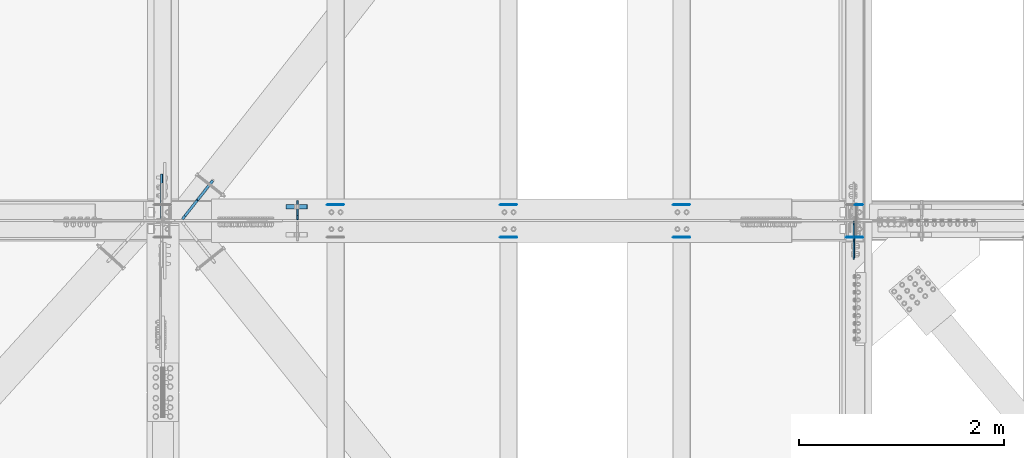
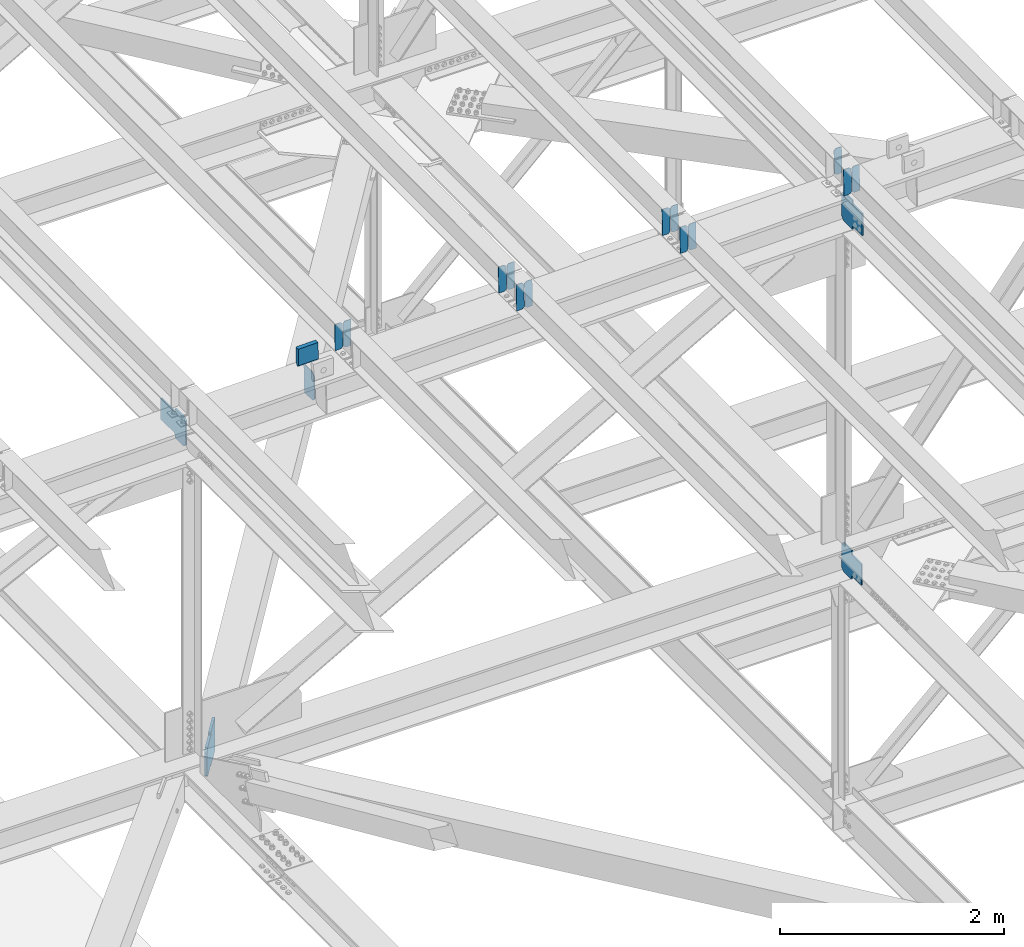
# One storey, part 3297 of 3843: 19 plates, 9 elements without a shape of their own.
"""IFC2X3 building model written with IfcOpenShell, lengths in millimetres."""

from ifc_helpers import new_model, si_unit, frame, origin_with_axes, place, context, subcontext, project, spatial, faceted_brep, material, type_object, element, aggregate, save


model = new_model("IFC2X3")

# Units and contexts
model_context = context("Model", 3, precision=1e-05, world=origin_with_axes())
body_context = subcontext(model_context, "Body", "Model", "MODEL_VIEW")
ifc_project = project(units=[si_unit("LENGTHUNIT", "METRE", prefix="MILLI"), si_unit("AREAUNIT", "SQUARE_METRE"), si_unit("VOLUMEUNIT", "CUBIC_METRE"), si_unit("MASSUNIT", "GRAM", prefix="KILO"), si_unit("TIMEUNIT", "SECOND"), si_unit("PLANEANGLEUNIT", "RADIAN"), si_unit("SOLIDANGLEUNIT", "STERADIAN"), si_unit("THERMODYNAMICTEMPERATUREUNIT", "DEGREE_CELSIUS"), si_unit("LUMINOUSINTENSITYUNIT", "LUMEN")], contexts=[model_context])

# Site, building, storey
site_placement = place(None, origin_with_axes())
site = spatial("IfcSite", under=ifc_project, at=site_placement, CompositionType="ELEMENT")
building_placement = place(site_placement, origin_with_axes())
building = spatial("IfcBuilding", under=site, at=building_placement, Name="Undefined", CompositionType="ELEMENT")
storey_placement = place(building_placement, origin_with_axes())
storey = spatial("IfcBuildingStorey", under=building, at=storey_placement, Name="Undefined", CompositionType="ELEMENT", Elevation=0.0)

# Assembly, plates
assembly_1_placement = place(storey_placement, origin_with_axes())
assembly_1 = element("IfcElementAssembly", 1, at=assembly_1_placement, inside=storey, Name="BEAM", AssemblyPlace="NOTDEFINED", PredefinedType="RIGID_FRAME")
ifc_material = material(Name="STEEL/A572-50")
plate_type_1 = type_object("IfcPlateType", PredefinedType="NOTDEFINED")
plate_1_placement = place(assembly_1_placement, frame((75405.9964782679, 33684.1789093083, 46268.5635563164), z_axis=(-0.021152098282546, -0.00202236699979404, 0.999774223897558), x_axis=(-0.999776269341419, 4.27870000128944e-05, -0.0211520550071887)))
plate_1 = element("IfcPlate", 2, at=plate_1_placement, type_object=plate_type_1, material=ifc_material, Name="PLATE", context=body_context, shape_type="Brep", body=[
    faceted_brep([(0.0, -3.17499999999927, 0.0), (6.83940015733242e-10, -3.17499999996653, 288.924999998613), (6.54836185276508e-10, 3.17500000001746, 288.924999998591), (0.0, 3.17499999999927, 0.0), (60.3250007643655, -3.17500000017753, 288.924999998606), (60.3250007643219, 3.17499999979918, 288.924999998584), (79.3750000013097, -3.17500000025029, 269.875000761494), (79.375000001266, 3.17499999972642, 269.875000761487), (79.375000000713, -3.17500000026484, 19.0499992370605), (79.3750000006985, 3.17499999971187, 19.0499992370533), (60.325000763667, -3.17500000020664, -1.45519152283669e-11), (60.3250007636234, 3.17499999977736, -3.63797880709171e-11)], [[[0, 1, 2, 3]], [[1, 4, 5, 2]], [[4, 6, 7, 5]], [[6, 8, 9, 7]], [[8, 10, 11, 9]], [[10, 0, 3, 11]], [[5, 7, 9, 11, 3, 2]], [[10, 8, 6, 4, 1, 0]]]),
])
plate_2_placement = place(assembly_1_placement, frame((75320.2906575777, 33684.1825772123, 46266.7502964254), z_axis=(-0.021152098282546, -0.00202236699979404, 0.999774223897558), x_axis=(-0.999776269341419, 4.27870000128944e-05, -0.0211520550071887)))
plate_2 = element("IfcPlate", 3, at=plate_2_placement, type_object=plate_type_1, material=ifc_material, Name="PLATE", context=body_context, shape_type="Brep", body=[
    faceted_brep([(4.36557456851006e-11, -3.17499999998836, 19.0499992370969), (6.11180439591408e-10, -3.17499999996653, 269.875000761516), (5.96628524363041e-10, 3.17500000001746, 269.875000761502), (1.45519152283669e-11, 3.17499999998836, 19.0499992370824), (19.0499992376572, -3.17500000003201, 288.924999998606), (19.0499992376281, 3.1749999999447, 288.924999998584), (79.3750000013242, -3.17500000025029, 288.924999998591), (79.3750000013097, 3.1749999997337, 288.92499999857), (79.3750000006548, -3.17500000026484, -2.18278728425503e-11), (79.3750000006403, 3.17499999969732, -2.91038304567337e-11), (19.0499992370023, -3.17500000005384, 0.0), (19.0499992369587, 3.17499999992287, -1.45519152283669e-11)], [[[0, 1, 2, 3]], [[1, 4, 5, 2]], [[4, 6, 7, 5]], [[6, 8, 9, 7]], [[8, 10, 11, 9]], [[10, 0, 3, 11]], [[5, 7, 9, 11, 3, 2]], [[10, 8, 6, 4, 1, 0]]]),
])
aggregate(assembly_1, [plate_1, plate_2])

assembly_2_placement = place(storey_placement, origin_with_axes())
assembly_2 = element("IfcElementAssembly", 4, at=assembly_2_placement, inside=storey, Name="BEAM", AssemblyPlace="NOTDEFINED", PredefinedType="RIGID_FRAME")
plate_3_placement = place(assembly_2_placement, frame((75405.9964782771, 34003.091399023, 46270.7774351257), z_axis=(-0.0211520977008331, -0.00680297999754112, 0.999753123639035), x_axis=(-0.999776269353726, 0.000143930000091341, -0.021151608007443)))
plate_3 = element("IfcPlate", 5, at=plate_3_placement, type_object=plate_type_1, material=ifc_material, Name="PLATE", context=body_context, shape_type="Brep", body=[
    faceted_brep([(0.0, -3.17499999999927, 0.0), (6.83940015733242e-10, -3.17499999996653, 288.924999998613), (6.54836185276508e-10, 3.17500000001746, 288.924999998591), (0.0, 3.17499999999927, 0.0), (60.3250007643655, -3.17500000017753, 288.924999998606), (60.3250007643219, 3.17499999979918, 288.924999998584), (79.3750000013097, -3.17500000025029, 269.875000761494), (79.375000001266, 3.17499999972642, 269.875000761487), (79.375000000713, -3.17500000026484, 19.0499992370605), (79.3750000006985, 3.17499999971187, 19.0499992370533), (60.325000763667, -3.17500000020664, -1.45519152283669e-11), (60.3250007636234, 3.17499999977736, -3.63797880709171e-11)], [[[0, 1, 2, 3]], [[1, 4, 5, 2]], [[4, 6, 7, 5]], [[6, 8, 9, 7]], [[8, 10, 11, 9]], [[10, 0, 3, 11]], [[5, 7, 9, 11, 3, 2]], [[10, 8, 6, 4, 1, 0]]]),
])
plate_4_placement = place(assembly_2_placement, frame((75320.2906575868, 34003.1037373807, 46268.9642135039), z_axis=(-0.0211520977008331, -0.00680297999754112, 0.999753123639035), x_axis=(-0.999776269353726, 0.000143930000091341, -0.021151608007443)))
plate_4 = element("IfcPlate", 6, at=plate_4_placement, type_object=plate_type_1, material=ifc_material, Name="PLATE", context=body_context, shape_type="Brep", body=[
    faceted_brep([(4.36557456851006e-11, -3.17499999998836, 19.0499992370969), (6.11180439591408e-10, -3.17499999996653, 269.875000761516), (5.96628524363041e-10, 3.17500000001746, 269.875000761502), (1.45519152283669e-11, 3.17499999998836, 19.0499992370824), (19.0499992376572, -3.17500000003201, 288.924999998606), (19.0499992376281, 3.1749999999447, 288.924999998584), (79.3750000013242, -3.17500000025029, 288.924999998591), (79.3750000013097, 3.1749999997337, 288.92499999857), (79.3750000006548, -3.17500000026484, -2.18278728425503e-11), (79.3750000006403, 3.17499999969732, -2.91038304567337e-11), (19.0499992370023, -3.17500000005384, 0.0), (19.0499992369587, 3.17499999992287, -1.45519152283669e-11)], [[[0, 1, 2, 3]], [[1, 4, 5, 2]], [[4, 6, 7, 5]], [[6, 8, 9, 7]], [[8, 10, 11, 9]], [[10, 0, 3, 11]], [[5, 7, 9, 11, 3, 2]], [[10, 8, 6, 4, 1, 0]]]),
])
aggregate(assembly_2, [plate_3, plate_4])

# Assembly, plate
assembly_3_placement = place(storey_placement, origin_with_axes())
assembly_3 = element("IfcElementAssembly", 7, at=assembly_3_placement, inside=storey, Name="BEAM", AssemblyPlace="NOTDEFINED", PredefinedType="RIGID_FRAME")
plate_5_placement = place(assembly_3_placement, frame((77095.0964783511, 34002.9786941155, 46307.2647120351), z_axis=(-0.0211520979019697, -0.00640368699966348, 0.999755760947221), x_axis=(-0.999776269349471, 0.000135482000054671, -0.0211516640074006)))
plate_5 = element("IfcPlate", 8, at=plate_5_placement, type_object=plate_type_1, material=ifc_material, Name="PLATE", context=body_context, shape_type="Brep", body=[
    faceted_brep([(0.0, -3.17499999999927, 0.0), (6.83940015733242e-10, -3.17499999996653, 288.924999998613), (6.54836185276508e-10, 3.17500000001746, 288.924999998591), (0.0, 3.17499999999927, 0.0), (60.3250007643655, -3.17500000017753, 288.924999998606), (60.3250007643219, 3.17499999979918, 288.924999998584), (79.3750000013097, -3.17500000025029, 269.875000761494), (79.375000001266, 3.17499999972642, 269.875000761487), (79.375000000713, -3.17500000026484, 19.0499992370605), (79.3750000006985, 3.17499999971187, 19.0499992370533), (60.325000763667, -3.17500000020664, -1.45519152283669e-11), (60.3250007636234, 3.17499999977736, -3.63797880709171e-11)], [[[0, 1, 2, 3]], [[1, 4, 5, 2]], [[4, 6, 7, 5]], [[6, 8, 9, 7]], [[8, 10, 11, 9]], [[10, 0, 3, 11]], [[5, 7, 9, 11, 3, 2]], [[10, 8, 6, 4, 1, 0]]]),
])
aggregate(assembly_3, [plate_5])

# Assembly, plates
assembly_4_placement = place(storey_placement, origin_with_axes())
assembly_4 = element("IfcElementAssembly", 9, at=assembly_4_placement, inside=storey, Name="BEAM", AssemblyPlace="NOTDEFINED", PredefinedType="RIGID_FRAME")
plate_6_placement = place(assembly_4_placement, frame((77095.096478274, 33684.2219342469, 46305.9063409992), z_axis=(-0.0211520976594328, -0.00216626100104622, 0.999773922483419), x_axis=(-0.999776269348977, 4.5491000049241e-05, -0.0211520490073722)))
plate_6 = element("IfcPlate", 10, at=plate_6_placement, type_object=plate_type_1, material=ifc_material, Name="PLATE", context=body_context, shape_type="Brep", body=[
    faceted_brep([(0.0, -3.17499999999927, 0.0), (6.83940015733242e-10, -3.17499999996653, 288.924999998613), (6.54836185276508e-10, 3.17500000001746, 288.924999998591), (0.0, 3.17499999999927, 0.0), (60.3250007643655, -3.17500000017753, 288.924999998606), (60.3250007643219, 3.17499999979918, 288.924999998584), (79.3750000013097, -3.17500000025029, 269.875000761494), (79.375000001266, 3.17499999972642, 269.875000761487), (79.375000000713, -3.17500000026484, 19.0499992370605), (79.3750000006985, 3.17499999971187, 19.0499992370533), (60.325000763667, -3.17500000020664, -1.45519152283669e-11), (60.3250007636234, 3.17499999977736, -3.63797880709171e-11)], [[[0, 1, 2, 3]], [[1, 4, 5, 2]], [[4, 6, 7, 5]], [[6, 8, 9, 7]], [[8, 10, 11, 9]], [[10, 0, 3, 11]], [[5, 7, 9, 11, 3, 2]], [[10, 8, 6, 4, 1, 0]]]),
])
plate_7_placement = place(assembly_4_placement, frame((77009.3906575827, 33684.2258631284, 46304.0930816536), z_axis=(-0.0211520976594328, -0.00216626100104622, 0.999773922483419), x_axis=(-0.999776269348977, 4.5491000049241e-05, -0.0211520490073722)))
plate_7 = element("IfcPlate", 11, at=plate_7_placement, type_object=plate_type_1, material=ifc_material, Name="PLATE", context=body_context, shape_type="Brep", body=[
    faceted_brep([(4.36557456851006e-11, -3.17499999998836, 19.0499992370969), (6.11180439591408e-10, -3.17499999996653, 269.875000761516), (5.96628524363041e-10, 3.17500000001746, 269.875000761502), (1.45519152283669e-11, 3.17499999998836, 19.0499992370824), (19.0499992376572, -3.17500000003201, 288.924999998606), (19.0499992376281, 3.1749999999447, 288.924999998584), (79.3750000013242, -3.17500000025029, 288.924999998591), (79.3750000013097, 3.1749999997337, 288.92499999857), (79.3750000006548, -3.17500000026484, -2.18278728425503e-11), (79.3750000006403, 3.17499999969732, -2.91038304567337e-11), (19.0499992370023, -3.17500000005384, 0.0), (19.0499992369587, 3.17499999992287, -1.45519152283669e-11)], [[[0, 1, 2, 3]], [[1, 4, 5, 2]], [[4, 6, 7, 5]], [[6, 8, 9, 7]], [[8, 10, 11, 9]], [[10, 0, 3, 11]], [[5, 7, 9, 11, 3, 2]], [[10, 8, 6, 4, 1, 0]]]),
])
aggregate(assembly_4, [plate_6, plate_7])

assembly_5_placement = place(storey_placement, origin_with_axes())
assembly_5 = element("IfcElementAssembly", 12, at=assembly_5_placement, inside=storey, Name="BEAM", AssemblyPlace="NOTDEFINED", PredefinedType="RIGID_FRAME")
plate_8_placement = place(assembly_5_placement, frame((73716.8964782651, 34003.1977922987, 46234.280966957), z_axis=(-0.0211520979699417, -0.00714367000215133, 0.999750747301731), x_axis=(-0.999776269348033, 0.000151137000043463, -0.0211515580073186)))
plate_8 = element("IfcPlate", 13, at=plate_8_placement, type_object=plate_type_1, material=ifc_material, Name="PLATE", context=body_context, shape_type="Brep", body=[
    faceted_brep([(0.0, -3.17499999999927, 0.0), (6.83940015733242e-10, -3.17499999996653, 288.924999998613), (6.54836185276508e-10, 3.17500000001746, 288.924999998591), (0.0, 3.17499999999927, 0.0), (60.3250007643655, -3.17500000017753, 288.924999998606), (60.3250007643219, 3.17499999979918, 288.924999998584), (79.3750000013097, -3.17500000025029, 269.875000761494), (79.375000001266, 3.17499999972642, 269.875000761487), (79.375000000713, -3.17500000026484, 19.0499992370605), (79.3750000006985, 3.17499999971187, 19.0499992370533), (60.325000763667, -3.17500000020664, -1.45519152283669e-11), (60.3250007636234, 3.17499999977736, -3.63797880709171e-11)], [[[0, 1, 2, 3]], [[1, 4, 5, 2]], [[4, 6, 7, 5]], [[6, 8, 9, 7]], [[8, 10, 11, 9]], [[10, 0, 3, 11]], [[5, 7, 9, 11, 3, 2]], [[10, 8, 6, 4, 1, 0]]]),
])
plate_9_placement = place(assembly_5_placement, frame((73631.1906575739, 34003.2107485552, 46232.4677496438), z_axis=(-0.0211520979699417, -0.00714367000215133, 0.999750747301731), x_axis=(-0.999776269348033, 0.000151137000043463, -0.0211515580073186)))
plate_9 = element("IfcPlate", 14, at=plate_9_placement, type_object=plate_type_1, material=ifc_material, Name="PLATE", context=body_context, shape_type="Brep", body=[
    faceted_brep([(4.36557456851006e-11, -3.17499999998836, 19.0499992370969), (6.11180439591408e-10, -3.17499999996653, 269.875000761516), (5.96628524363041e-10, 3.17500000001746, 269.875000761502), (1.45519152283669e-11, 3.17499999998836, 19.0499992370824), (19.0499992376572, -3.17500000003201, 288.924999998606), (19.0499992376281, 3.1749999999447, 288.924999998584), (79.3750000013242, -3.17500000025029, 288.924999998591), (79.3750000013097, 3.1749999997337, 288.92499999857), (79.3750000006548, -3.17500000026484, -2.18278728425503e-11), (79.3750000006403, 3.17499999969732, -2.91038304567337e-11), (19.0499992370023, -3.17500000005384, 0.0), (19.0499992369587, 3.17499999992287, -1.45519152283669e-11)], [[[0, 1, 2, 3]], [[1, 4, 5, 2]], [[4, 6, 7, 5]], [[6, 8, 9, 7]], [[8, 10, 11, 9]], [[10, 0, 3, 11]], [[5, 7, 9, 11, 3, 2]], [[10, 8, 6, 4, 1, 0]]]),
])
aggregate(assembly_5, [plate_8, plate_9])

assembly_6_placement = place(storey_placement, origin_with_axes())
assembly_6 = element("IfcElementAssembly", 15, at=assembly_6_placement, inside=storey, Name="BEAM", AssemblyPlace="NOTDEFINED", PredefinedType="RIGID_FRAME")
plate_10_placement = place(assembly_6_placement, frame((73716.8964782659, 33684.1789031377, 46232.8275160392), z_axis=(-0.021152098282546, -0.00202236699979404, 0.999774223897558), x_axis=(-0.999776269341419, 4.27870000128944e-05, -0.0211520550071887)))
plate_10 = element("IfcPlate", 16, at=plate_10_placement, type_object=plate_type_1, material=ifc_material, Name="PLATE", context=body_context, shape_type="Brep", body=[
    faceted_brep([(0.0, -3.17499999999927, 0.0), (6.83940015733242e-10, -3.17499999996653, 288.924999998613), (6.54836185276508e-10, 3.17500000001746, 288.924999998591), (0.0, 3.17499999999927, 0.0), (60.3250007643655, -3.17500000017753, 288.924999998606), (60.3250007643219, 3.17499999979918, 288.924999998584), (79.3750000013097, -3.17500000025029, 269.875000761494), (79.375000001266, 3.17499999972642, 269.875000761487), (79.375000000713, -3.17500000026484, 19.0499992370605), (79.3750000006985, 3.17499999971187, 19.0499992370533), (60.325000763667, -3.17500000020664, -1.45519152283669e-11), (60.3250007636234, 3.17499999977736, -3.63797880709171e-11)], [[[0, 1, 2, 3]], [[1, 4, 5, 2]], [[4, 6, 7, 5]], [[6, 8, 9, 7]], [[8, 10, 11, 9]], [[10, 0, 3, 11]], [[5, 7, 9, 11, 3, 2]], [[10, 8, 6, 4, 1, 0]]]),
])
plate_11_placement = place(assembly_6_placement, frame((73631.1906575747, 33684.182571042, 46231.0142561484), z_axis=(-0.021152098282546, -0.00202236699979404, 0.999774223897558), x_axis=(-0.999776269341419, 4.27870000128944e-05, -0.0211520550071887)))
plate_11 = element("IfcPlate", 17, at=plate_11_placement, type_object=plate_type_1, material=ifc_material, Name="PLATE", context=body_context, shape_type="Brep", body=[
    faceted_brep([(4.36557456851006e-11, -3.17499999998836, 19.0499992370969), (6.11180439591408e-10, -3.17499999996653, 269.875000761516), (5.96628524363041e-10, 3.17500000001746, 269.875000761502), (1.45519152283669e-11, 3.17499999998836, 19.0499992370824), (19.0499992376572, -3.17500000003201, 288.924999998606), (19.0499992376281, 3.1749999999447, 288.924999998584), (79.3750000013242, -3.17500000025029, 288.924999998591), (79.3750000013097, 3.1749999997337, 288.92499999857), (79.3750000006548, -3.17500000026484, -2.18278728425503e-11), (79.3750000006403, 3.17499999969732, -2.91038304567337e-11), (19.0499992370023, -3.17500000005384, 0.0), (19.0499992369587, 3.17499999992287, -1.45519152283669e-11)], [[[0, 1, 2, 3]], [[1, 4, 5, 2]], [[4, 6, 7, 5]], [[6, 8, 9, 7]], [[8, 10, 11, 9]], [[10, 0, 3, 11]], [[5, 7, 9, 11, 3, 2]], [[10, 8, 6, 4, 1, 0]]]),
])
aggregate(assembly_6, [plate_10, plate_11])

assembly_7_placement = place(storey_placement, origin_with_axes())
assembly_7 = element("IfcElementAssembly", 18, at=assembly_7_placement, inside=storey, Name="BEAM", AssemblyPlace="NOTDEFINED", PredefinedType="RIGID_FRAME")
plate_12_placement = place(assembly_7_placement, frame((72027.7964782784, 34003.2790771855, 46197.7739598394), z_axis=(-0.0211520982902439, -0.0074183040013959, 0.999748747187844), x_axis=(-0.999776269341256, 0.000156948000085566, -0.0211515160072627)))
plate_12 = element("IfcPlate", 19, at=plate_12_placement, type_object=plate_type_1, material=ifc_material, Name="PLATE", context=body_context, shape_type="Brep", body=[
    faceted_brep([(0.0, -3.17499999999927, 0.0), (6.83940015733242e-10, -3.17499999996653, 288.924999998613), (6.54836185276508e-10, 3.17500000001746, 288.924999998591), (0.0, 3.17499999999927, 0.0), (60.3250007643655, -3.17500000017753, 288.924999998606), (60.3250007643219, 3.17499999979918, 288.924999998584), (79.3750000013097, -3.17500000025029, 269.875000761494), (79.375000001266, 3.17499999972642, 269.875000761487), (79.375000000713, -3.17500000026484, 19.0499992370605), (79.3750000006985, 3.17499999971187, 19.0499992370533), (60.325000763667, -3.17500000020664, -1.45519152283669e-11), (60.3250007636234, 3.17499999977736, -3.63797880709171e-11)], [[[0, 1, 2, 3]], [[1, 4, 5, 2]], [[4, 6, 7, 5]], [[6, 8, 9, 7]], [[8, 10, 11, 9]], [[10, 0, 3, 11]], [[5, 7, 9, 11, 3, 2]], [[10, 8, 6, 4, 1, 0]]]),
])
plate_13_placement = place(assembly_7_placement, frame((71942.0906575872, 34003.2925315358, 46195.9607461541), z_axis=(-0.0211520982902439, -0.0074183040013959, 0.999748747187844), x_axis=(-0.999776269341256, 0.000156948000085566, -0.0211515160072627)))
plate_13 = element("IfcPlate", 20, at=plate_13_placement, type_object=plate_type_1, material=ifc_material, Name="PLATE", context=body_context, shape_type="Brep", body=[
    faceted_brep([(4.36557456851006e-11, -3.17499999998836, 19.0499992370969), (6.11180439591408e-10, -3.17499999996653, 269.875000761516), (5.96628524363041e-10, 3.17500000001746, 269.875000761502), (1.45519152283669e-11, 3.17499999998836, 19.0499992370824), (19.0499992376572, -3.17500000003201, 288.924999998606), (19.0499992376281, 3.1749999999447, 288.924999998584), (79.3750000013242, -3.17500000025029, 288.924999998591), (79.3750000013097, 3.1749999997337, 288.92499999857), (79.3750000006548, -3.17500000026484, -2.18278728425503e-11), (79.3750000006403, 3.17499999969732, -2.91038304567337e-11), (19.0499992370023, -3.17500000005384, 0.0), (19.0499992369587, 3.17499999992287, -1.45519152283669e-11)], [[[0, 1, 2, 3]], [[1, 4, 5, 2]], [[4, 6, 7, 5]], [[6, 8, 9, 7]], [[8, 10, 11, 9]], [[10, 0, 3, 11]], [[5, 7, 9, 11, 3, 2]], [[10, 8, 6, 4, 1, 0]]]),
])
aggregate(assembly_7, [plate_12, plate_13])

assembly_8_placement = place(storey_placement, origin_with_axes())
assembly_8 = element("IfcElementAssembly", 21, at=assembly_8_placement, inside=storey, Name="BEAM", AssemblyPlace="NOTDEFINED", PredefinedType="RIGID_FRAME")
plate_type_2 = type_object("IfcPlateType", PredefinedType="NOTDEFINED")
plate_14_placement = place(assembly_8_placement, frame((71571.7735521455, 33856.6125, 45819.9763019932), z_axis=(-0.0216342480057937, 0.0, 0.999765952267441), x_axis=(0.0, 1.0, 0.0)))
plate_14 = element("IfcPlate", 22, at=plate_14_placement, type_object=plate_type_2, material=ifc_material, Name="PL", context=body_context, shape_type="Brep", body=[
    faceted_brep([(0.0, -4.76250000000073, 38.0999999999985), (0.0, -4.76249999810534, 279.400001530797), (0.0, 4.76250000185973, 279.400001530805), (0.0, 4.76250000000073, 38.0999999999985), (38.0999984741211, -4.76249999785796, 317.500000005042), (38.0999984741211, 4.76250000210712, 317.50000000505), (184.150000000009, -4.76249999999709, 317.5), (184.150000000009, 4.76249999999709, 317.5), (184.150000000009, -4.76249999999709, 0.0), (184.150000000009, 4.76249999999709, 0.0), (38.0999984741211, -4.76249999996799, 0.0), (38.0999984741211, 4.76249999998254, 0.0)], [[[0, 1, 2, 3]], [[1, 4, 5, 2]], [[4, 6, 7, 5]], [[6, 8, 9, 7]], [[8, 10, 11, 9]], [[10, 0, 3, 11]], [[5, 7, 9, 11, 3, 2]], [[10, 8, 6, 4, 1, 0]]]),
])
plate_type_3 = type_object("IfcPlateType", PredefinedType="NOTDEFINED")
plate_15_placement = place(assembly_8_placement, frame((71458.4330476478, 33981.628125, 46376.3164907603), z_axis=(0.0217666070074993, 0.0, -0.999763079343992), x_axis=(0.999763079343992, 0.0, 0.0217666070075027)))
plate_15 = element("IfcPlate", 23, at=plate_15_placement, type_object=plate_type_3, material=ifc_material, Name="PLATE", context=body_context, shape_type="Brep", body=[
    faceted_brep([(203.200005058941, -22.2250000000058, -1.16415321826935e-10), (7.27595761418343e-12, -22.2250000000058, -7.27595761418343e-12), (7.27595761418343e-12, 22.2250000000058, -7.27595761418343e-12), (203.200005058941, 22.2250000000058, -1.16415321826935e-10), (203.838531807472, -22.2250000000058, 0.00187068080413155), (203.838531807472, 22.2250000000058, 0.00187068080413155), (203.310341304641, -22.2250000000058, 180.861817383484), (0.04046799018397, -22.2250000000058, 180.907287948779), (203.245434494536, 0.0133131837355904, 203.086833080139), (0.0454396034692763, 0.0133129994646879, 203.132287829787), (0.0404679902494536, 22.2250000000058, 180.907288225317), (203.310341303353, 22.2250000000058, 180.861817822159)], [[[0, 1, 2, 3]], [[4, 0, 3, 5]], [[1, 0, 4, 6, 7]], [[7, 6, 8, 9]], [[2, 1, 7, 9, 10]], [[5, 3, 2, 10, 11]], [[6, 4, 5, 11, 8]], [[10, 9, 8, 11]]]),
])

# Assembly, plate
assembly_9_placement = place(storey_placement, origin_with_axes())
assembly_9 = element("IfcElementAssembly", 24, at=assembly_9_placement, inside=storey, Name="BEAM", AssemblyPlace="NOTDEFINED", PredefinedType="RIGID_FRAME")
plate_type_4 = type_object("IfcPlateType", PredefinedType="NOTDEFINED")
plate_16_placement = place(assembly_9_placement, frame((77001.6874995861, 33838.3562499382, 42139.0711776414), z_axis=(0.0, -0.707106781186682, 0.707106781186413), x_axis=(0.0, -0.707106781186548, -0.707106781186548)))
plate_16 = element("IfcPlate", 25, at=plate_16_placement, type_object=plate_type_4, material=ifc_material, Name="PLATE", context=body_context, shape_type="Brep", body=[
    faceted_brep([(0.0, -6.3499999046162, 0.0), (-179.600813047069, -6.35000000000582, 179.600813047073), (-179.600813047069, 6.35000000000582, 179.600813047073), (7.27595761418343e-12, 6.3499999046162, 0.0), (-179.600813047073, -6.35000000000582, 224.502093652191), (-179.600813047073, 6.35000000000582, 224.502093652191), (-75.7666016477051, -6.35000000000582, 328.336305051562), (-75.7666016477051, 6.35000000000582, 328.336305051562), (-52.668384245364, -6.35000000000582, 305.238087651742), (-52.668384245364, 6.35000000000582, 305.238087651742), (-48.5482077772176, -6.35000000000582, 302.485073751268), (-48.5482077772176, 6.35000000000582, 302.485073751268), (-43.6881282591785, -6.35000000000582, 301.518343828684), (-43.6881282591785, 6.35000000000582, 301.518343828684), (-38.8280487411539, -6.35000000000582, 302.485073751275), (-38.8280487411539, 6.35000000000582, 302.485073751275), (-34.7078722730075, -6.35000000000582, 305.238087651742), (-34.7078722730075, 6.35000000000582, 305.238087651742), (82.0354574365047, -6.35000000000582, 421.981417361261), (82.0354574365047, 6.35000000000582, 421.981417361261), (243.680067614972, -6.35000000000582, 260.336807182794), (243.680067614972, 6.35000000000582, 260.336807182794), (126.93673790546, -6.35000000000582, 143.593477473281), (126.93673790546, 6.35000000000582, 143.593477473281), (124.183724004986, -6.35000000000582, 139.473301005139), (124.183724004986, 6.35000000000582, 139.473301005139), (123.216994082402, -6.35000000000582, 134.613221487107), (123.216994082402, 6.35000000000582, 134.613221487107), (124.183724004994, -6.35000000000582, 129.753141969071), (124.183724004994, 6.35000000000582, 129.753141969071), (126.93673790546, -6.35000000000582, 125.632965500929), (126.93673790546, 6.35000000000582, 125.632965500929), (148.735492004496, -6.35000000000582, 103.834211399357), (148.735492004496, 6.35000000000582, 103.834211399357), (44.9012806051323, -6.35000000000582, -1.45519152283669e-11), (44.9012806051323, 6.35000000000582, -1.45519152283669e-11)], [[[0, 1, 2, 3]], [[1, 4, 5, 2]], [[4, 6, 7, 5]], [[6, 8, 9, 7]], [[8, 10, 11, 9]], [[10, 12, 13, 11]], [[12, 14, 15, 13]], [[14, 16, 17, 15]], [[16, 18, 19, 17]], [[18, 20, 21, 19]], [[20, 22, 23, 21]], [[22, 24, 25, 23]], [[24, 26, 27, 25]], [[26, 28, 29, 27]], [[28, 30, 31, 29]], [[30, 32, 33, 31]], [[32, 34, 35, 33]], [[34, 0, 3, 35]], [[5, 7, 9, 11, 13, 15, 17, 19, 21, 23, 25, 27, 29, 31, 33, 35, 3, 2]], [[34, 32, 30, 28, 26, 24, 22, 20, 18, 16, 14, 12, 10, 8, 6, 4, 1, 0]]]),
])

# Plate
plate_17_placement = place(assembly_8_placement, frame((77000.8937503737, 33834.3874999491, 45969.3457745376), z_axis=(0.0, -0.707106781186682, 0.707106781186413), x_axis=(0.0, -0.707106781186548, -0.707106781186548)))
plate_17 = element("IfcPlate", 26, at=plate_17_placement, type_object=plate_type_4, material=ifc_material, Name="PLATE", context=body_context, shape_type="Brep", body=[
    faceted_brep([(0.0, -6.3499999046162, 0.0), (-179.46387894213, -6.35000000000582, 179.46387894213), (-179.46387894213, 6.35000000000582, 179.46387894213), (7.27595761418343e-12, 6.3499999046162, 0.0), (-179.463878941897, -6.35000000000582, 224.365159547495), (-179.463878941897, 6.35000000000582, 224.365159547495), (-68.3332094431244, -6.35000000000582, 335.495829046271), (-68.3332094431244, 6.35000000000582, 335.495829046271), (-49.9340834781033, -6.35000000000582, 317.09670308125), (-49.9340834781033, 6.35000000000582, 317.09670308125), (-45.8139070099642, -6.35000000000582, 314.34368918078), (-45.8139070099642, 6.35000000000582, 314.34368918078), (-40.953827491925, -6.35000000000582, 313.376959258196), (-40.953827491925, 6.35000000000582, 313.376959258196), (-36.0937479738932, -6.35000000000582, 314.343689180776), (-36.0937479738932, 6.35000000000582, 314.343689180776), (-31.9735715057468, -6.35000000000582, 317.09670308125), (-31.9735715057468, 6.35000000000582, 317.09670308125), (84.7697582037872, -6.35000000000582, 433.840032790788), (84.7697582037872, 6.35000000000582, 433.840032790788), (255.394624503271, -6.35000000000582, 263.2151664913), (255.394624503271, 6.35000000000582, 263.2151664913), (138.65129479373, -6.35000000000582, 146.471836781759), (138.65129479373, 6.35000000000582, 146.471836781759), (135.898280893263, -6.35000000000582, 142.351660313616), (135.898280893263, 6.35000000000582, 142.351660313616), (134.931550970679, -6.35000000000582, 137.491580795588), (134.931550970679, 6.35000000000582, 137.491580795588), (135.898280893263, -6.35000000000582, 132.631501277552), (135.898280893263, 6.35000000000582, 132.631501277552), (138.651294793737, -6.35000000000582, 128.511324809406), (138.651294793737, 6.35000000000582, 128.511324809406), (156.031950102829, -6.35000000000582, 111.130669497703), (156.031950102829, 6.35000000000582, 111.130669497703), (44.9012806051323, -6.35000000000582, -1.45519152283669e-11), (44.9012806051323, 6.35000000000582, -1.45519152283669e-11)], [[[0, 1, 2, 3]], [[1, 4, 5, 2]], [[4, 6, 7, 5]], [[6, 8, 9, 7]], [[8, 10, 11, 9]], [[10, 12, 13, 11]], [[12, 14, 15, 13]], [[14, 16, 17, 15]], [[16, 18, 19, 17]], [[18, 20, 21, 19]], [[20, 22, 23, 21]], [[22, 24, 25, 23]], [[24, 26, 27, 25]], [[26, 28, 29, 27]], [[28, 30, 31, 29]], [[30, 32, 33, 31]], [[32, 34, 35, 33]], [[34, 0, 3, 35]], [[5, 7, 9, 11, 13, 15, 17, 19, 21, 23, 25, 27, 29, 31, 33, 35, 3, 2]], [[34, 32, 30, 28, 26, 24, 22, 20, 18, 16, 14, 12, 10, 8, 6, 4, 1, 0]]]),
])

plate_type_5 = type_object("IfcPlateType", PredefinedType="NOTDEFINED")
plate_18_placement = place(assembly_8_placement, frame((70242.1124996318, 33856.6125, 45823.1590921898), z_axis=(0.0, 0.707106781186548, 0.707106781186548), x_axis=(5.70000238222118e-08, 0.707106781186546, -0.707106781186546)))
plate_18 = element("IfcPlate", 27, at=plate_18_placement, type_object=plate_type_5, material=ifc_material, Name="PLATE", context=body_context, shape_type="Brep", body=[
    faceted_brep([(0.0, -9.52500000000146, 0.0), (-179.366715657274, -9.52499999999418, 179.366715657248), (-179.366715657274, 9.52499999999418, 179.366715657248), (0.0, 9.52500000000146, 0.0), (-179.366715656826, -9.52499999999418, 224.267996262832), (-179.366715656826, 9.52499999999418, 224.267996262832), (-68.2360461568533, -9.52499999999418, 335.398665762827), (-68.2360461568533, 9.52499999999418, 335.398665762827), (-47.5125439119147, -9.52499999999418, 314.675163491531), (-47.5125439119147, 9.52499999999418, 314.675163491531), (-43.3923674437683, -9.52499999999418, 311.92214959105), (-43.3923674437683, 9.52499999999418, 311.92214959105), (-38.5322879257146, -9.52499999999418, 310.955419668495), (-38.5322879257146, 9.52499999999418, 310.955419668495), (-33.6722084076464, -9.52499999999418, 311.922149591101), (-33.6722084076464, 9.52499999999418, 311.922149591101), (-29.5520319394709, -9.52499999999418, 314.675163491615), (-29.5520319394709, 9.52499999999418, 314.675163491615), (141.07283451168, -9.52499999999418, 485.300029942751), (141.07283451168, 9.52499999999418, 485.300029942751), (302.717444690134, -9.52499999999418, 323.655419764294), (302.717444690134, 9.52499999999418, 323.655419764294), (132.092578238997, -9.52499999999418, 153.03055331315), (132.092578238997, 9.52499999999418, 153.03055331315), (129.339564338487, -9.52499999999418, 148.910376844968), (129.339564338487, 9.52499999999418, 148.910376844968), (128.372834415874, -9.52499999999418, 144.050297326903), (128.372834415874, 9.52499999999418, 144.050297326903), (129.339564338443, -9.52499999999418, 139.190217808849), (129.339564338443, 9.52499999999418, 139.190217808849), (132.092578238909, -9.52499999999418, 135.070041340707), (132.092578238909, 9.52499999999418, 135.070041340707), (156.031950102854, -9.52499999999418, 111.130669497732), (156.031950102854, 9.52499999999418, 111.130669497732), (44.9012806055835, -9.52499999999418, 4.65661287307739e-10), (44.9012806055835, 9.52499999999418, 4.65661287307739e-10)], [[[0, 1, 2, 3]], [[1, 4, 5, 2]], [[4, 6, 7, 5]], [[6, 8, 9, 7]], [[8, 10, 11, 9]], [[10, 12, 13, 11]], [[12, 14, 15, 13]], [[14, 16, 17, 15]], [[16, 18, 19, 17]], [[18, 20, 21, 19]], [[20, 22, 23, 21]], [[22, 24, 25, 23]], [[24, 26, 27, 25]], [[26, 28, 29, 27]], [[28, 30, 31, 29]], [[30, 32, 33, 31]], [[32, 34, 35, 33]], [[34, 0, 3, 35]], [[5, 7, 9, 11, 13, 15, 17, 19, 21, 23, 25, 27, 29, 31, 33, 35, 3, 2]], [[34, 32, 30, 28, 26, 24, 22, 20, 18, 16, 14, 12, 10, 8, 6, 4, 1, 0]]]),
])

aggregate(assembly_8, [plate_14, plate_15, plate_17, plate_18])

plate_type_6 = type_object("IfcPlateType", PredefinedType="NOTDEFINED")
plate_19_placement = place(assembly_9_placement, frame((70446.0081213057, 33860.4994686214, 42104.152931189), z_axis=(0.0, 0.0, 1.0), x_axis=(0.618560525050791, 0.785737155064523, 0.0)))
plate_19 = element("IfcPlate", 28, at=plate_19_placement, type_object=plate_type_6, material=ifc_material, Name="STIFFENER", context=body_context, shape_type="Brep", body=[
    faceted_brep([(0.0, -12.6999999999971, 38.0999999999913), (1.57808244694024e-07, -12.7000000000698, 279.400255757311), (1.5777550288476e-07, 12.6999999998807, 279.400255757319), (0.0, 12.6999999999971, 38.0999999999913), (38.0999986533716, -12.7000000000262, 317.500254231185), (38.0999986533352, 12.6999999999243, 317.500254231192), (227.293955966772, -12.6999999999607, 317.500254232153), (227.293955966772, 12.7000000000189, 317.50025423216), (232.154035484622, -12.6999999999607, 318.466984154678), (232.154035484622, 12.7000000000262, 318.466984154686), (236.274211952652, -12.6999999999462, 321.219998054963), (236.274211952667, 12.7000000000189, 321.21999805497), (239.027225853148, -12.6999999999534, 325.340174522848), (239.027225853162, 12.7000000000189, 325.340174522855), (239.993955775935, -12.6999999999534, 330.200254040647), (239.99395577595, 12.7000000000262, 330.200254040654), (239.993955776663, -12.6999999999462, 342.900254232183), (239.993955776677, 12.7000000000189, 342.90025423219), (479.812102647542, -12.6999999999898, 342.900254225504), (479.812102647556, 12.6999999999753, 342.900254225511), (479.812102402619, -12.700000000099, -25.4000000013548), (479.812102402619, 12.6999999998661, -25.4000000013475), (239.993955700993, -12.700000000048, -25.4000000000015), (239.993955700993, 12.6999999999243, -25.3999999999942), (239.99395570159, -12.7000000000407, -12.69999980992), (239.99395570159, 12.6999999999243, -12.69999980992), (239.027225779166, -12.7000000000335, -7.83992029167712), (239.02722577918, 12.6999999999316, -7.83992029166984), (236.274211878714, -12.7000000000335, -3.71974382330518), (236.274211878728, 12.6999999999389, -3.7197438232979), (232.15403541048, -12.7000000000407, -0.966729922663944), (232.154035410495, 12.6999999999243, -0.966729922656668), (227.293955892295, -12.7000000000407, -1.45519152283669e-11), (227.293955892295, 12.6999999999389, -7.27595761418343e-12), (38.1000000000058, -12.7000000000844, 2.18278728425503e-11), (38.1000000000058, 12.7000000000262, 4.36557456851006e-11)], [[[0, 1, 2, 3]], [[1, 4, 5, 2]], [[4, 6, 7, 5]], [[6, 8, 9, 7]], [[8, 10, 11, 9]], [[10, 12, 13, 11]], [[12, 14, 15, 13]], [[14, 16, 17, 15]], [[16, 18, 19, 17]], [[18, 20, 21, 19]], [[20, 22, 23, 21]], [[22, 24, 25, 23]], [[24, 26, 27, 25]], [[26, 28, 29, 27]], [[28, 30, 31, 29]], [[30, 32, 33, 31]], [[32, 34, 35, 33]], [[34, 0, 3, 35]], [[5, 7, 9, 11, 13, 15, 17, 19, 21, 23, 25, 27, 29, 31, 33, 35, 3, 2]], [[34, 32, 30, 28, 26, 24, 22, 20, 18, 16, 14, 12, 10, 8, 6, 4, 1, 0]]]),
])

aggregate(assembly_9, [plate_16, plate_19])

save(model, "model.ifc")
